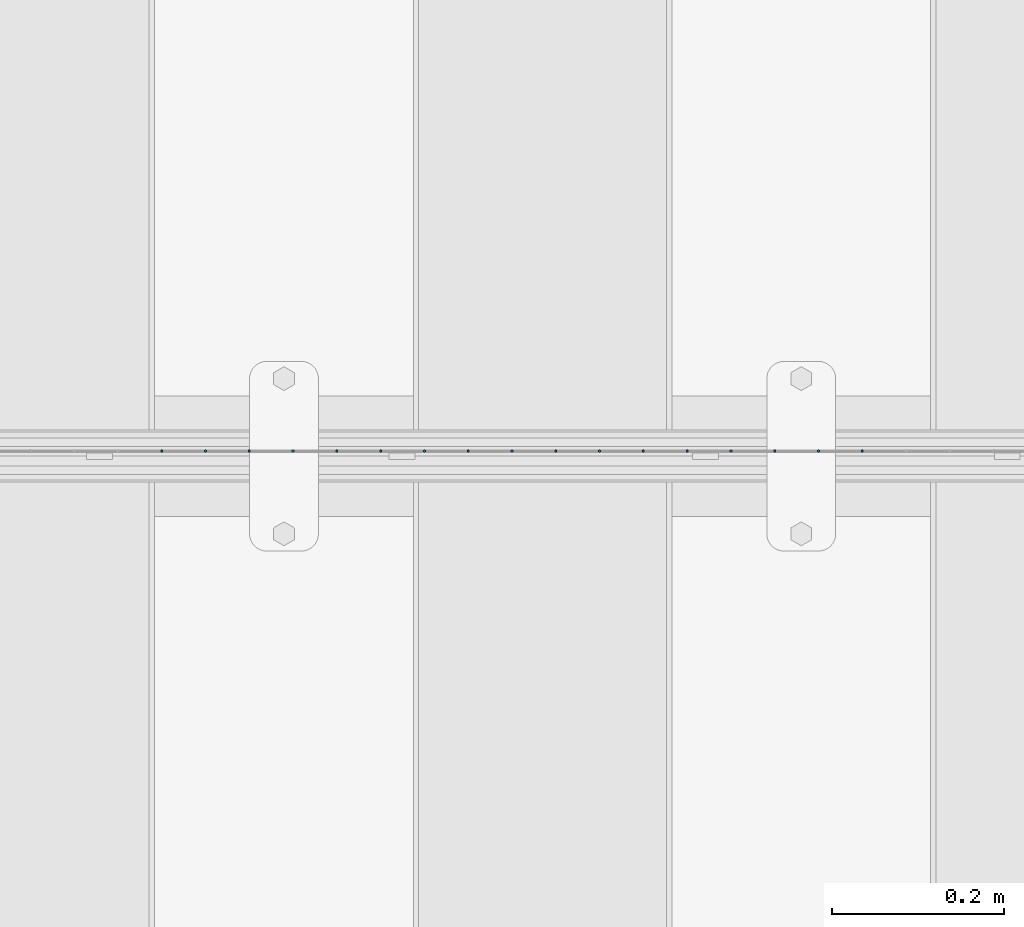
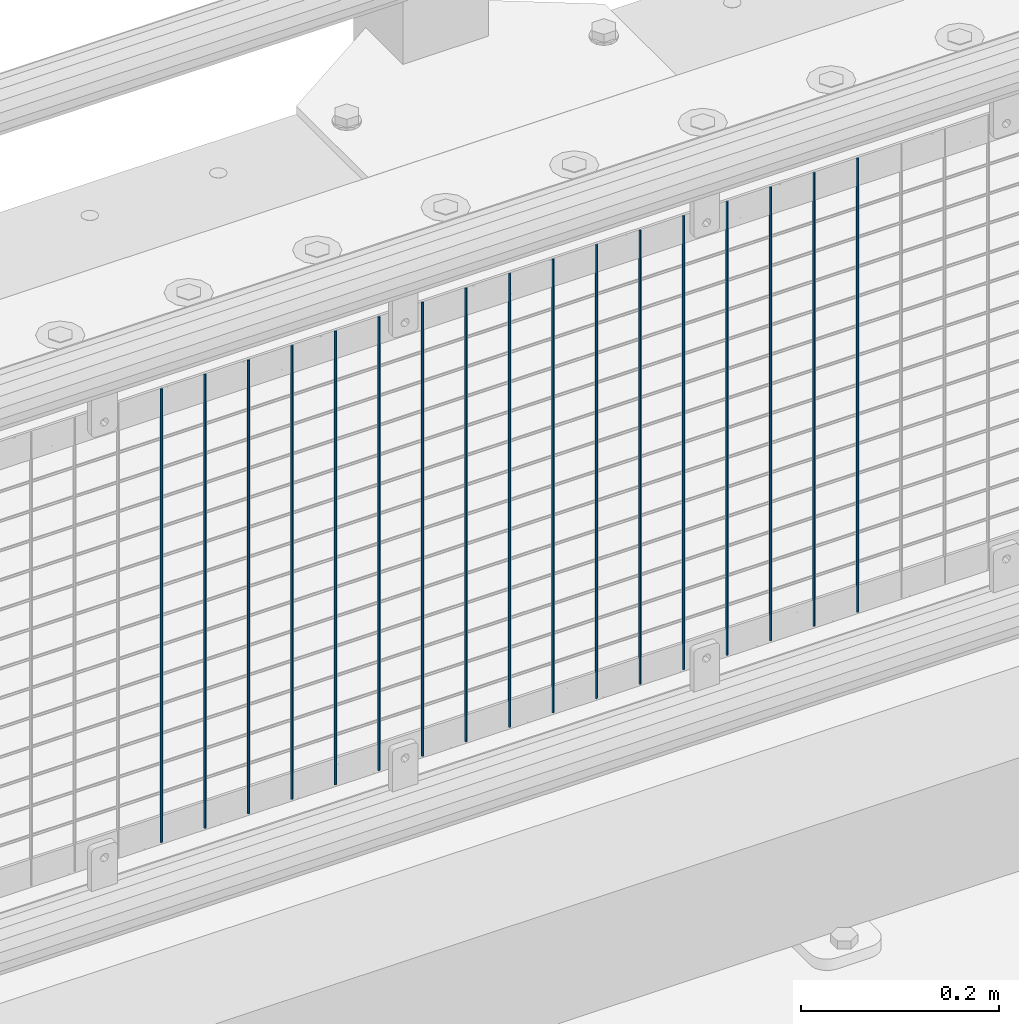
# One storey, part 62 of 242: 17 columns.
"""IFC2X3 building model written with IfcOpenShell, lengths in millimetres."""

from ifc_helpers import new_model, si_unit, frame, origin_with_axes, place, context, subcontext, project, spatial, faceted_brep, material, type_object, element, save


model = new_model("IFC2X3")

# Units and contexts
model_context = context("Model", 3, precision=1e-05, world=origin_with_axes())
body_context = subcontext(model_context, "Body", "Model", "MODEL_VIEW")
ifc_project = project(units=[si_unit("LENGTHUNIT", "METRE", prefix="MILLI"), si_unit("AREAUNIT", "SQUARE_METRE"), si_unit("VOLUMEUNIT", "CUBIC_METRE"), si_unit("MASSUNIT", "GRAM", prefix="KILO"), si_unit("TIMEUNIT", "SECOND"), si_unit("PLANEANGLEUNIT", "RADIAN"), si_unit("SOLIDANGLEUNIT", "STERADIAN"), si_unit("THERMODYNAMICTEMPERATUREUNIT", "DEGREE_CELSIUS"), si_unit("LUMINOUSINTENSITYUNIT", "LUMEN")], contexts=[model_context])

# Site, building, storey
site_placement = place(None, origin_with_axes())
site = spatial("IfcSite", under=ifc_project, at=site_placement, CompositionType="ELEMENT")
building_placement = place(site_placement, origin_with_axes())
building = spatial("IfcBuilding", under=site, at=building_placement, Name="Standard", CompositionType="ELEMENT")
storey_placement = place(building_placement, origin_with_axes())
storey = spatial("IfcBuildingStorey", under=building, at=storey_placement, Name="Undefined", CompositionType="ELEMENT", Elevation=0.0)

# Columns
ifc_material = material(Name="Misc_Undefined")
column_type = type_object("IfcColumnType", Name="D3", PredefinedType="NOTDEFINED")
for number, where, z_axis, x_axis in (
    (1, (-40479.175, -19329.5, 353.02), (-1.0, 0.0, 0.0), (0.0, 0.0, 1.0)),
    (2, (-40529.968, -19329.5, 353.02), (-1.0, 0.0, 0.0), (0.0, 0.0, 1.0)),
    (3, (-40580.761, -19329.5, 353.02), (-1.0, 0.0, 0.0), (0.0, 0.0, 1.0)),
    (4, (-40631.554, -19329.5, 353.02), (-1.0, 0.0, 0.0), (0.0, 0.0, 1.0)),
    (5, (-40682.347, -19329.5, 353.02), (-1.0, 0.0, 0.0), (0.0, 0.0, 1.0)),
    (6, (-40733.14, -19329.5, 353.02), (-1.0, 0.0, 0.0), (0.0, 0.0, 1.0)),
    (7, (-40783.933, -19329.5, 353.02), (-1.0, 0.0, 0.0), (0.0, 0.0, 1.0)),
    (8, (-40834.726, -19329.5, 353.02), (-1.0, 0.0, 0.0), (0.0, 0.0, 1.0)),
    (9, (-40885.519, -19329.5, 353.02), (-1.0, 0.0, 0.0), (0.0, 0.0, 1.0)),
    (10, (-40936.312, -19329.5, 353.02), (-1.0, 0.0, 0.0), (0.0, 0.0, 1.0)),
    (11, (-40987.105, -19329.5, 353.02), (-1.0, 0.0, 0.0), (0.0, 0.0, 1.0)),
    (12, (-41037.898, -19329.5, 353.02), (-1.0, 0.0, 0.0), (0.0, 0.0, 1.0)),
    (13, (-41088.691, -19329.5, 353.02), (-1.0, 0.0, 0.0), (0.0, 0.0, 1.0)),
    (14, (-41139.484, -19329.5, 353.02), (-1.0, 0.0, 0.0), (0.0, 0.0, 1.0)),
    (15, (-41190.277, -19329.5, 353.02), (-1.0, 0.0, 0.0), (0.0, 0.0, 1.0)),
    (16, (-41241.07, -19329.5, 353.02), (-1.0, 0.0, 0.0), (0.0, 0.0, 1.0)),
    (17, (-41291.863, -19329.5, 353.02), (-1.0, 0.0, 0.0), (0.0, 0.0, 1.0)),
):
    element("IfcColumn", number, at=place(storey_placement, frame(where, z_axis=z_axis, x_axis=x_axis)), inside=storey, type_object=column_type, material=ifc_material, ObjectType="D3", context=body_context, shape_type="Brep", body=[
        faceted_brep([(0.0, -1.50000000000364, 0.0), (-3.63797880709171e-12, -0.750000000003638, -1.29903810567669), (560.0, -0.75, -1.29903810567703), (560.0, -1.5, 0.0), (0.0, 0.749999999996362, -1.29903810567669), (560.0, 0.75, -1.29903810567703), (-3.63797880709171e-12, 1.49999999999636, 0.0), (560.0, 1.5, 0.0), (0.0, 0.749999999996362, 1.29903810567669), (560.0, 0.75, 1.29903810567703), (-3.63797880709171e-12, -0.750000000003638, 1.29903810567669), (560.0, -0.75, 1.29903810567703)], [[[0, 1, 2, 3]], [[1, 4, 5, 2]], [[4, 6, 7, 5]], [[6, 8, 9, 7]], [[8, 10, 11, 9]], [[10, 0, 3, 11]], [[5, 7, 9, 11, 3, 2]], [[10, 8, 6, 4, 1, 0]]]),
    ])

save(model, "model.ifc")
